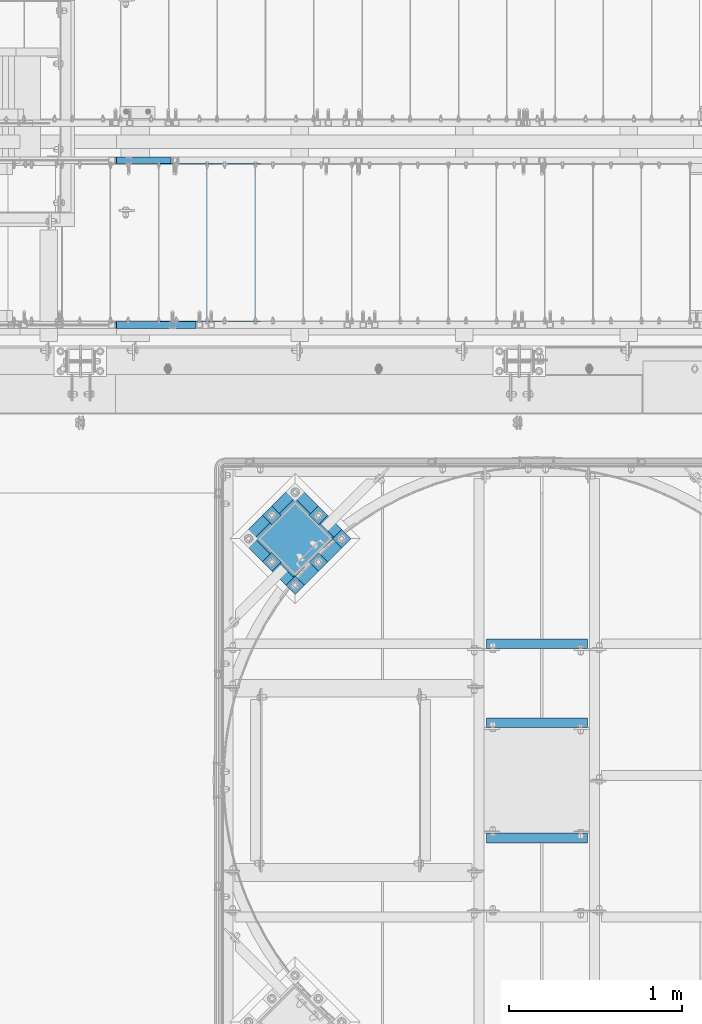
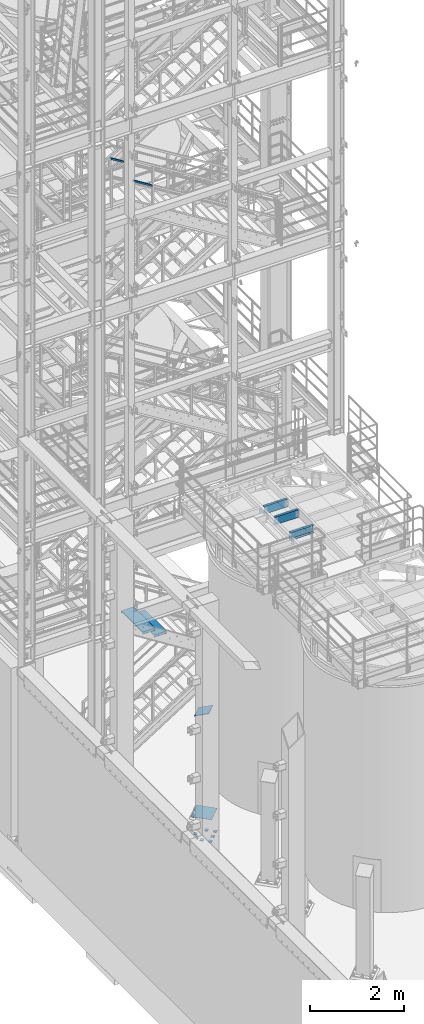
# One storey, part 1142 of 1876: 12 beams, 3 members, 8 elements without a shape of their own.
"""IFC2X3 building model written with IfcOpenShell, lengths in millimetres."""

import ifcopenshell
import ifcopenshell.guid

model = None  # the IFC model being written
_history = None  # IfcOwnerHistory: only IFC2X3 demands one
_inside = {}  # id of a spatial element -> (the spatial element, [elements in it])
_under = {}  # id of a project, library or spatial element -> (it, [spatial elements below it])
_declared = {}  # id of a project -> (the project, [libraries it declares])
_typed = {}  # id of a type object -> (the type object, [elements of that type])
_made_of = {}  # id of a material, layer set ... -> (it, [elements and type objects made of it])


def new_model(schema):
    """Start an empty IFC model of exactly this schema.

    Asked for "IFC4X3", IfcOpenShell would pick the latest addendum, in which some entities
    have other attributes; the version numbers below select the first issue.
    IFC2X3 requires an IfcOwnerHistory on every rooted entity: one is made here for all.
    """
    global model, _history
    if schema == "IFC4X3":
        model = ifcopenshell.file(schema_version=(4, 3, 0, 0))
    else:
        model = ifcopenshell.file(schema=schema)
    _inside.clear()
    _under.clear()
    _declared.clear()
    _typed.clear()
    _made_of.clear()
    _history = None
    if model.schema == "IFC2X3":
        org = make("IfcOrganization", Name="unknown")
        user = make(
            "IfcPersonAndOrganization",
            ThePerson=make("IfcPerson", FamilyName="unknown"),
            TheOrganization=org,
        )
        app = make(
            "IfcApplication",
            ApplicationDeveloper=org,
            Version="unknown",
            ApplicationFullName="unknown",
            ApplicationIdentifier="unknown",
        )
        _history = make(
            "IfcOwnerHistory",
            OwningUser=user,
            OwningApplication=app,
            ChangeAction="ADDED",
            CreationDate=0,
        )
    return model


def make(cls, **values):
    """One entity of the class cls with the attributes given. An attribute that is None is left unset."""
    return model.create_entity(
        cls, **{name: value for name, value in values.items() if value is not None}
    )


def rooted(cls, **values):
    """An entity with a GlobalId (a new one), such as an element, a storey or a relation."""
    return make(cls, GlobalId=ifcopenshell.guid.new(), OwnerHistory=_history, **values)


def si_unit(unit_type, name, prefix=None):
    """IfcSIUnit, for example si_unit("LENGTHUNIT", "METRE", prefix="MILLI")."""
    return make("IfcSIUnit", UnitType=unit_type, Prefix=prefix, Name=name)


def assignment(units):
    """IfcUnitAssignment: the units of a project."""
    return None if units is None else make("IfcUnitAssignment", Units=units)


def point(xyz):
    """IfcCartesianPoint."""
    return None if xyz is None else make("IfcCartesianPoint", Coordinates=xyz)


def direction(xyz):
    """IfcDirection."""
    return None if xyz is None else make("IfcDirection", DirectionRatios=xyz)


def frame(location, z_axis=None, x_axis=None):
    """IfcAxis2Placement3D, a coordinate frame: its origin and axes. An axis left out is left unset."""
    return make(
        "IfcAxis2Placement3D",
        Location=point(location),
        Axis=direction(z_axis),
        RefDirection=direction(x_axis),
    )


def origin_with_axes():
    """The frame at (0, 0, 0) with the z axis (0, 0, 1) and the x axis (1, 0, 0) written out."""
    return frame((0.0, 0.0, 0.0), z_axis=(0.0, 0.0, 1.0), x_axis=(1.0, 0.0, 0.0))


def place(relative_to, where):
    """IfcLocalPlacement: puts the frame where relative to a parent placement (None: the world)."""
    return make(
        "IfcLocalPlacement", PlacementRelTo=relative_to, RelativePlacement=where
    )


def context(
    kind, dimensions, precision=None, world=None, true_north=None, identifier=None
):
    """IfcGeometricRepresentationContext, for example the 3D "Model" context."""
    return make(
        "IfcGeometricRepresentationContext",
        ContextIdentifier=identifier,
        ContextType=kind,
        CoordinateSpaceDimension=dimensions,
        Precision=precision,
        WorldCoordinateSystem=world,
        TrueNorth=true_north,
    )


def subcontext(parent, identifier, kind, view, scale=None):
    """IfcGeometricRepresentationSubContext, for example "Body" below "Model"."""
    return make(
        "IfcGeometricRepresentationSubContext",
        ContextIdentifier=identifier,
        ContextType=kind,
        ParentContext=parent,
        TargetScale=scale,
        TargetView=view,
    )


def project(units=None, contexts=None):
    """IfcProject with its units and contexts."""
    return rooted(
        "IfcProject",
        Name="project",
        RepresentationContexts=contexts,
        UnitsInContext=assignment(units),
    )


def spatial(cls, under=None, at=None, **own):
    """A site, building, storey or space (cls), placed at a placement, below another one or the project."""
    s = rooted(cls, ObjectPlacement=at, **own)
    if under is not None:
        _under.setdefault(under.id(), (under, []))[1].append(s)
    return s


def faces_of(points, faces, orient=None, outer=None):
    """IfcFace entities. A face is a list of loops; a loop is a list of indices into points, from 0.

    orient and outer hold one flag for each loop. By default every Orientation is true, the
    first loop of a face is its IfcFaceOuterBound and the others are IfcFaceBound.
    """
    made = []
    for i, loops in enumerate(faces):
        bounds = []
        for j, loop in enumerate(loops):
            is_outer = j == 0 if outer is None else outer[i][j]
            bounds.append(
                make(
                    "IfcFaceOuterBound" if is_outer else "IfcFaceBound",
                    Bound=make("IfcPolyLoop", Polygon=[points[k] for k in loop]),
                    Orientation=True if orient is None else orient[i][j],
                )
            )
        made.append(make("IfcFace", Bounds=bounds))
    return made


def faceted_brep(points, faces, orient=None, outer=None, voids=None):
    """IfcFacetedBrep: a solid bounded by flat faces; with voids (closed shells), ...WithVoids."""
    shared = [point(p) for p in points]
    hull = make("IfcClosedShell", CfsFaces=faces_of(shared, faces, orient, outer))
    if voids is None:
        return make("IfcFacetedBrep", Outer=hull)
    return make(
        "IfcFacetedBrepWithVoids",
        Outer=hull,
        Voids=[
            make(cls, CfsFaces=faces_of(shared, fs, o, b)) for cls, fs, o, b in voids
        ],
    )


def shape(context_of_items, identifier, shape_type, items):
    """IfcShapeRepresentation: the items that make up one representation, for example the "Body"."""
    return make(
        "IfcShapeRepresentation",
        ContextOfItems=context_of_items,
        RepresentationIdentifier=identifier,
        RepresentationType=shape_type,
        Items=items,
    )


def material(Name=None, Category=None):
    """IfcMaterial."""
    return make("IfcMaterial", Name=Name, Category=Category)


def made_of(thing, what):
    """Note that an element or type object is made of a material, layer set ...; save() writes the relation."""
    if what is not None:
        _made_of.setdefault(what.id(), (what, []))[1].append(thing)
    return thing


def type_object(cls, material=None, **own):
    """A type object (cls), such as IfcWallType, which elements share."""
    return made_of(rooted(cls, **own), material)


def element(
    cls,
    number,
    at=None,
    inside=None,
    cuts=None,
    type_object=None,
    material=None,
    context=None,
    identifier="Body",
    shape_type=None,
    held_by="IfcProductDefinitionShape",
    body=None,
    shapes=None,
    **own,
):
    """One element of the class cls, such as IfcWall. Its Tag is "e" and its number.

    at: its placement. inside: the storey or other place that contains it. cuts: it is an
    opening in that element (IfcRelVoidsElement). A single representation is given by context,
    identifier, shape_type and body (its items); several are given by shapes. held_by: the class
    of the entity that holds the representations. save() writes the other relations.
    """
    e = rooted(cls, Tag="e%d" % number, ObjectPlacement=at, **own)
    if body is not None:
        shapes = [shape(context, identifier, shape_type, body)]
    if shapes is not None:
        e.Representation = make(held_by, Representations=shapes)
    if inside is not None:
        _inside.setdefault(inside.id(), (inside, []))[1].append(e)
    if cuts is not None:
        rooted(
            "IfcRelVoidsElement", RelatingBuildingElement=cuts, RelatedOpeningElement=e
        )
    if type_object is not None:
        _typed.setdefault(type_object.id(), (type_object, []))[1].append(e)
    return made_of(e, material)


def aggregate(whole, parts):
    """IfcRelAggregates: a whole, such as a stair, and the parts it consists of."""
    return rooted("IfcRelAggregates", RelatingObject=whole, RelatedObjects=parts)


def save(model, path):
    """Write the relations noted so far, then the file.

    IfcRelAggregates (storeys below a building ...), IfcRelContainedInSpatialStructure (elements
    in a storey), IfcRelDefinesByType, IfcRelAssociatesMaterial and IfcRelDeclares: one each for
    every whole, place, type object, material and project.
    """
    for whole, parts in _under.values():
        aggregate(whole, parts)
    for where, things in _inside.values():
        rooted(
            "IfcRelContainedInSpatialStructure",
            RelatedElements=things,
            RelatingStructure=where,
        )
    for kind, things in _typed.values():
        rooted("IfcRelDefinesByType", RelatedObjects=things, RelatingType=kind)
    for what, things in _made_of.values():
        rooted("IfcRelAssociatesMaterial", RelatedObjects=things, RelatingMaterial=what)
    for by, libraries in _declared.values():
        rooted("IfcRelDeclares", RelatingContext=by, RelatedDefinitions=libraries)
    model.write(path)


model = new_model("IFC2X3")

# Units and contexts
model_context = context("Model", 3, precision=1e-05, world=origin_with_axes())
body_context = subcontext(model_context, "Body", "Model", "MODEL_VIEW")
ifc_project = project(units=[si_unit("LENGTHUNIT", "METRE", prefix="MILLI"), si_unit("AREAUNIT", "SQUARE_METRE"), si_unit("VOLUMEUNIT", "CUBIC_METRE"), si_unit("MASSUNIT", "GRAM", prefix="KILO"), si_unit("TIMEUNIT", "SECOND"), si_unit("PLANEANGLEUNIT", "RADIAN"), si_unit("SOLIDANGLEUNIT", "STERADIAN"), si_unit("THERMODYNAMICTEMPERATUREUNIT", "DEGREE_CELSIUS"), si_unit("LUMINOUSINTENSITYUNIT", "LUMEN")], contexts=[model_context])

# Site, building, storey
site_placement = place(None, origin_with_axes())
site = spatial("IfcSite", under=ifc_project, at=site_placement, CompositionType="ELEMENT")
building_placement = place(site_placement, origin_with_axes())
building = spatial("IfcBuilding", under=site, at=building_placement, Name="Undefined", CompositionType="ELEMENT")
storey_placement = place(building_placement, origin_with_axes())
storey = spatial("IfcBuildingStorey", under=building, at=storey_placement, Name="Undefined", CompositionType="ELEMENT", Elevation=0.0)

# Assembly, beam
assembly_1_placement = place(storey_placement, origin_with_axes())
assembly_1 = element("IfcElementAssembly", 1, at=assembly_1_placement, inside=storey, Name="BEAM", AssemblyPlace="NOTDEFINED", PredefinedType="RIGID_FRAME")
ifc_material_1 = material(Name="STEEL/A36")
beam_type_1 = type_object("IfcBeamType", Name="C8X11.5", PredefinedType="NOTDEFINED")
beam_1_placement = place(assembly_1_placement, frame((4876.80190734863, -9204.28937988218, 7896.225), z_axis=(0.0, 0.0, -1.0), x_axis=(1.0, 0.0, 0.0)))
beam_1 = element("IfcBeam", 2, at=beam_1_placement, type_object=beam_type_1, material=ifc_material_1, Name="BEAM", ObjectType="C8X11.5", context=body_context, shape_type="Brep", body=[
    faceted_brep([(12.7014315012184, 28.5750000000007, -101.6), (12.7014315012184, 28.5750000000007, 101.6), (596.901431501219, 28.5750000000007, 101.6), (596.901431501219, 28.5750000000007, -101.6), (12.7014315012184, -28.5750000000007, 101.6), (596.901431501219, -28.5750000000007, 101.6), (12.7014315012184, -28.5750000000007, 96.8355949999996), (596.901431501219, -28.5750000000007, 96.8355949999996), (12.7014315012184, 22.2250000000004, 88.3723149999996), (596.901431501219, 22.2250000000004, 88.3723149999996), (12.7014315012184, 22.2250000000004, -88.3723149999996), (596.901431501219, 22.2250000000004, -88.3723149999996), (12.7014315012184, -28.5750000000007, -96.8355949999996), (596.901431501219, -28.5750000000007, -96.8355949999996), (12.7014315012184, -28.5750000000007, -101.6), (596.901431501219, -28.5750000000007, -101.6)], [[[0, 1, 2, 3]], [[1, 4, 5, 2]], [[4, 6, 7, 5]], [[6, 8, 9, 7]], [[8, 10, 11, 9]], [[10, 12, 13, 11]], [[12, 14, 15, 13]], [[14, 0, 3, 15]], [[5, 7, 9, 11, 13, 15, 3, 2]], [[14, 12, 10, 8, 6, 4, 1, 0]]]),
])
aggregate(assembly_1, [beam_1])

assembly_2_placement = place(storey_placement, origin_with_axes())
assembly_2 = element("IfcElementAssembly", 3, at=assembly_2_placement, inside=storey, Name="BEAM", AssemblyPlace="NOTDEFINED", PredefinedType="RIGID_FRAME")
beam_2_placement = place(assembly_2_placement, frame((4876.80333884985, -9871.03937988219, 7896.225), z_axis=(0.0, 0.0, 1.0), x_axis=(1.0, 0.0, 0.0)))
beam_2 = element("IfcBeam", 4, at=beam_2_placement, type_object=beam_type_1, material=ifc_material_1, Name="BEAM", ObjectType="C8X11.5", context=body_context, shape_type="Brep", body=[
    faceted_brep([(12.7000000000007, 28.5749999999998, -101.6), (12.7000000000007, 28.5749999999998, 101.6), (596.900000000001, 28.5750000000007, 101.6), (596.900000000001, 28.5750000000007, -101.6), (12.7000000000007, -28.5749999999998, 101.6), (596.900000000001, -28.5750000000007, 101.6), (12.7000000000007, -28.5749999999998, 96.8355949999996), (596.900000000001, -28.5750000000007, 96.8355949999996), (12.7000000000007, 22.2250000000004, 88.3723149999996), (596.900000000001, 22.2250000000004, 88.3723149999996), (12.7000000000007, 22.2250000000004, -88.3723149999996), (596.900000000001, 22.2250000000004, -88.3723149999996), (12.7000000000007, -28.5749999999998, -96.8355949999996), (596.900000000001, -28.5750000000007, -96.8355949999996), (12.7000000000007, -28.5749999999998, -101.6), (596.900000000001, -28.5750000000007, -101.6)], [[[0, 1, 2, 3]], [[1, 4, 5, 2]], [[4, 6, 7, 5]], [[6, 8, 9, 7]], [[8, 10, 11, 9]], [[10, 12, 13, 11]], [[12, 14, 15, 13]], [[14, 0, 3, 15]], [[5, 7, 9, 11, 13, 15, 3, 2]], [[14, 12, 10, 8, 6, 4, 1, 0]]]),
])
aggregate(assembly_2, [beam_2])

assembly_3_placement = place(storey_placement, origin_with_axes())
assembly_3 = element("IfcElementAssembly", 5, at=assembly_3_placement, inside=storey, Name="BEAM", AssemblyPlace="NOTDEFINED", PredefinedType="RIGID_FRAME")
beam_3_placement = place(assembly_3_placement, frame((4876.80333884985, -8747.08935546873, 7896.225), z_axis=(0.0, 0.0, -1.0), x_axis=(1.0, 0.0, 0.0)))
beam_3 = element("IfcBeam", 6, at=beam_3_placement, type_object=beam_type_1, material=ifc_material_1, Name="BEAM", ObjectType="C8X11.5", context=body_context, shape_type="Brep", body=[
    faceted_brep([(12.7000000000007, 28.5749999999998, -101.6), (12.7000000000007, 28.5749999999998, 101.6), (596.900000000001, 28.5750000000007, 101.6), (596.900000000001, 28.5750000000007, -101.6), (12.7000000000007, -28.5749999999998, 101.6), (596.900000000001, -28.5750000000007, 101.6), (12.7000000000007, -28.5749999999998, 96.8355949999996), (596.900000000001, -28.5750000000007, 96.8355949999996), (12.7000000000007, 22.2250000000004, 88.3723149999996), (596.900000000001, 22.2250000000004, 88.3723149999996), (12.7000000000007, 22.2250000000004, -88.3723149999996), (596.900000000001, 22.2250000000004, -88.3723149999996), (12.7000000000007, -28.5749999999998, -96.8355949999996), (596.900000000001, -28.5750000000007, -96.8355949999996), (12.7000000000007, -28.5749999999998, -101.6), (596.900000000001, -28.5750000000007, -101.6)], [[[0, 1, 2, 3]], [[1, 4, 5, 2]], [[4, 6, 7, 5]], [[6, 8, 9, 7]], [[8, 10, 11, 9]], [[10, 12, 13, 11]], [[12, 14, 15, 13]], [[14, 0, 3, 15]], [[5, 7, 9, 11, 13, 15, 3, 2]], [[14, 12, 10, 8, 6, 4, 1, 0]]]),
])
aggregate(assembly_3, [beam_3])

# Assembly, member
assembly_4_placement = place(storey_placement, origin_with_axes())
assembly_4 = element("IfcElementAssembly", 7, at=assembly_4_placement, inside=storey, Name="COLUMN", AssemblyPlace="NOTDEFINED", PredefinedType="RIGID_FRAME")
member_type_1 = type_object("IfcMemberType", PredefinedType="NOTDEFINED")
member_1_placement = place(assembly_4_placement, frame((3889.24355300666, -8245.19773813303, 2749.16704824061), z_axis=(0.707106781186548, 0.707106781186547, 0.0), x_axis=(-0.664463024761457, 0.664463024761458, -0.342020141877214)))
member_1 = element("IfcMember", 8, at=member_1_placement, type_object=member_type_1, material=ifc_material_1, Name="PLATE", context=body_context, shape_type="Brep", body=[
    faceted_brep([(0.0, 6.35000000000042, -165.100000000026), (0.0, 6.35000000000042, 165.100000000029), (337.061384869998, 6.34999999999997, 165.099999999921), (337.061384869996, 6.34999999999997, -165.100000000135), (1.81898940354586e-12, -6.34999999999849, 165.100000000029), (337.061384869998, -6.3499999999994, 165.099999999921), (0.0, -6.34999999999894, -165.100000000026), (337.061384869998, -6.3499999999994, -165.100000000136)], [[[0, 1, 2, 3]], [[1, 4, 5, 2]], [[4, 6, 7, 5]], [[6, 0, 3, 7]], [[5, 7, 3, 2]], [[6, 4, 1, 0]]]),
])
aggregate(assembly_4, [member_1])

# Assembly, beams
assembly_5_placement = place(storey_placement, origin_with_axes())
assembly_5 = element("IfcElementAssembly", 9, at=assembly_5_placement, inside=storey, Name="TEMPLATE", AssemblyPlace="NOTDEFINED", PredefinedType="RIGID_FRAME")
beam_type_2 = type_object("IfcBeamType", PredefinedType="NOTDEFINED")
beam_4_placement = place(assembly_5_placement, frame((4079.3646457972, -8112.02961055577, -542.925), z_axis=(-0.707106781186548, 0.707106781186547, 0.0), x_axis=(-0.707106781186547, -0.707106781186548, 0.0)))
beam_4 = element("IfcBeam", 10, at=beam_4_placement, type_object=beam_type_2, material=ifc_material_1, Name="PLATE", context=body_context, shape_type="Brep", body=[
    faceted_brep([(0.0, 9.52499999999998, -38.1000000000058), (-9.09494701772928e-13, 9.52499999999998, 38.1000000000076), (76.2000000000762, 9.52499999999998, 38.1000000000058), (76.2000000000762, 9.52499999999998, -38.1000000000058), (-9.09494701772928e-13, -9.52499999999998, 38.1000000000076), (76.2000000000762, -9.52499999999998, 38.1000000000058), (0.0, -9.52499999999998, -38.1000000000058), (76.2000000000762, -9.52499999999998, -38.1000000000058)], [[[0, 1, 2, 3]], [[1, 4, 5, 2]], [[4, 6, 7, 5]], [[6, 0, 3, 7]], [[5, 7, 3, 2]], [[6, 4, 1, 0]]]),
])
beam_5_placement = place(assembly_5_placement, frame((3944.66080398105, -7977.32576873962, -542.925), z_axis=(-0.707106781186548, 0.707106781186547, 0.0), x_axis=(-0.707106781186547, -0.707106781186548, 0.0)))
beam_5 = element("IfcBeam", 11, at=beam_5_placement, type_object=beam_type_2, material=ifc_material_1, Name="PLATE", context=body_context, shape_type="Brep", body=[
    faceted_brep([(0.0, 9.52499999999998, -38.1000000000058), (-9.09494701772928e-13, 9.52499999999998, 38.1000000000076), (76.2000000000762, 9.52499999999998, 38.1000000000058), (76.2000000000762, 9.52499999999998, -38.1000000000058), (-9.09494701772928e-13, -9.52499999999998, 38.1000000000076), (76.2000000000762, -9.52499999999998, 38.1000000000058), (0.0, -9.52499999999998, -38.1000000000058), (76.2000000000762, -9.52499999999998, -38.1000000000058)], [[[0, 1, 2, 3]], [[1, 4, 5, 2]], [[4, 6, 7, 5]], [[6, 0, 3, 7]], [[5, 7, 3, 2]], [[6, 4, 1, 0]]]),
])
beam_6_placement = place(assembly_5_placement, frame((3944.66080398105, -8246.73345237192, -542.925), z_axis=(-0.707106781186548, 0.707106781186547, 0.0), x_axis=(-0.707106781186547, -0.707106781186548, 0.0)))
beam_6 = element("IfcBeam", 12, at=beam_6_placement, type_object=beam_type_2, material=ifc_material_1, Name="PLATE", context=body_context, shape_type="Brep", body=[
    faceted_brep([(0.0, 9.52499999999998, -38.1000000000058), (-9.09494701772928e-13, 9.52499999999998, 38.1000000000076), (76.2000000000762, 9.52499999999998, 38.1000000000058), (76.2000000000762, 9.52499999999998, -38.1000000000058), (-9.09494701772928e-13, -9.52499999999998, 38.1000000000076), (76.2000000000762, -9.52499999999998, 38.1000000000058), (0.0, -9.52499999999998, -38.1000000000058), (76.2000000000762, -9.52499999999998, -38.1000000000058)], [[[0, 1, 2, 3]], [[1, 4, 5, 2]], [[4, 6, 7, 5]], [[6, 0, 3, 7]], [[5, 7, 3, 2]], [[6, 4, 1, 0]]]),
])
beam_7_placement = place(assembly_5_placement, frame((3675.25312034875, -7977.32576873961, -542.925), z_axis=(-0.707106781186548, 0.707106781186547, 0.0), x_axis=(-0.707106781186547, -0.707106781186548, 0.0)))
beam_7 = element("IfcBeam", 13, at=beam_7_placement, type_object=beam_type_2, material=ifc_material_1, Name="PLATE", context=body_context, shape_type="Brep", body=[
    faceted_brep([(0.0, 9.52499999999998, -38.1000000000058), (-9.09494701772928e-13, 9.52499999999998, 38.1000000000076), (76.2000000000762, 9.52499999999998, 38.1000000000058), (76.2000000000762, 9.52499999999998, -38.1000000000058), (-9.09494701772928e-13, -9.52499999999998, 38.1000000000076), (76.2000000000762, -9.52499999999998, 38.1000000000058), (0.0, -9.52499999999998, -38.1000000000058), (76.2000000000762, -9.52499999999998, -38.1000000000058)], [[[0, 1, 2, 3]], [[1, 4, 5, 2]], [[4, 6, 7, 5]], [[6, 0, 3, 7]], [[5, 7, 3, 2]], [[6, 4, 1, 0]]]),
])
beam_8_placement = place(assembly_5_placement, frame((3809.9569621649, -8381.43729418807, -542.925), z_axis=(-0.707106781186548, 0.707106781186547, 0.0), x_axis=(-0.707106781186547, -0.707106781186548, 0.0)))
beam_8 = element("IfcBeam", 14, at=beam_8_placement, type_object=beam_type_2, material=ifc_material_1, Name="PLATE", context=body_context, shape_type="Brep", body=[
    faceted_brep([(0.0, 9.52499999999998, -38.1000000000058), (-9.09494701772928e-13, 9.52499999999998, 38.1000000000076), (76.2000000000762, 9.52499999999998, 38.1000000000058), (76.2000000000762, 9.52499999999998, -38.1000000000058), (-9.09494701772928e-13, -9.52499999999998, 38.1000000000076), (76.2000000000762, -9.52499999999998, 38.1000000000058), (0.0, -9.52499999999998, -38.1000000000058), (76.2000000000762, -9.52499999999998, -38.1000000000058)], [[[0, 1, 2, 3]], [[1, 4, 5, 2]], [[4, 6, 7, 5]], [[6, 0, 3, 7]], [[5, 7, 3, 2]], [[6, 4, 1, 0]]]),
])
beam_9_placement = place(assembly_5_placement, frame((3675.25312034875, -8246.73345237191, -542.925), z_axis=(-0.707106781186548, 0.707106781186547, 0.0), x_axis=(-0.707106781186547, -0.707106781186548, 0.0)))
beam_9 = element("IfcBeam", 15, at=beam_9_placement, type_object=beam_type_2, material=ifc_material_1, Name="PLATE", context=body_context, shape_type="Brep", body=[
    faceted_brep([(0.0, 9.52499999999998, -38.1000000000058), (-9.09494701772928e-13, 9.52499999999998, 38.1000000000076), (76.2000000000762, 9.52499999999998, 38.1000000000058), (76.2000000000762, 9.52499999999998, -38.1000000000058), (-9.09494701772928e-13, -9.52499999999998, 38.1000000000076), (76.2000000000762, -9.52499999999998, 38.1000000000058), (0.0, -9.52499999999998, -38.1000000000058), (76.2000000000762, -9.52499999999998, -38.1000000000058)], [[[0, 1, 2, 3]], [[1, 4, 5, 2]], [[4, 6, 7, 5]], [[6, 0, 3, 7]], [[5, 7, 3, 2]], [[6, 4, 1, 0]]]),
])
beam_type_3 = type_object("IfcBeamType", PredefinedType="NOTDEFINED")
beam_10_placement = place(assembly_5_placement, frame((3944.66080398091, -7977.32576873953, 40.4815), z_axis=(0.707106781186547, -0.707106781186548, 0.0), x_axis=(-0.707106781186547, -0.707106781186548, 0.0)))
beam_10 = element("IfcBeam", 16, at=beam_10_placement, type_object=beam_type_3, material=ifc_material_1, Name="TEMPLATE", context=body_context, shape_type="Brep", body=[
    faceted_brep([(9.09494701772928e-13, 2.3815, -228.600000000035), (-9.09494701772928e-13, 2.3815, 228.60000000004), (457.200000000363, 2.3815, 228.60000000004), (457.200000000362, 2.3815, -228.600000000037), (-9.09494701772928e-13, -2.3815, 228.60000000004), (457.200000000363, -2.3815, 228.60000000004), (9.09494701772928e-13, -2.3815, -228.600000000035), (457.200000000362, -2.3815, -228.600000000037)], [[[0, 1, 2, 3]], [[1, 4, 5, 2]], [[4, 6, 7, 5]], [[6, 0, 3, 7]], [[5, 7, 3, 2]], [[6, 4, 1, 0]]]),
])
aggregate(assembly_5, [beam_4, beam_5, beam_6, beam_7, beam_8, beam_9, beam_10])

# Assembly, member
assembly_6_placement = place(storey_placement, origin_with_axes())
assembly_6 = element("IfcElementAssembly", 17, at=assembly_6_placement, inside=storey, Name="RAIL", AssemblyPlace="NOTDEFINED", PredefinedType="RIGID_FRAME")
ifc_material_2 = material()
member_type_2 = type_object("IfcMemberType", Name="HSS1-1/2X1-1/2X1/8", PredefinedType="NOTDEFINED")
member_2_placement = place(assembly_6_placement, frame((3229.61016453362, -6902.45000114819, 15801.439963085), z_axis=(0.526640055094465, 0.0, 0.850088379152485), x_axis=(-0.850088379152485, 0.0, 0.526640055094466)))
member_2 = element("IfcMember", 18, at=member_2_placement, type_object=member_type_2, material=ifc_material_2, Name="RAIL", ObjectType="HSS1-1/2X1-1/2X1/8", context=body_context, shape_type="Brep", body=[
    faceted_brep([(12.5746792883347, 15.8749992829999, -15.874999283018), (12.5746792883347, -15.8749992829999, -15.874999283018), (567.668633956618, -15.8749992829999, -15.8749992834546), (567.668633956618, 15.8749992829999, -15.8749992834546), (32.2441882524263, -15.8749992829999, 15.8749992829798), (576.706483818847, -15.8749992829999, 15.8749992825542), (32.2441882524263, 15.8749992829999, 15.8749992829798), (576.706483818847, 15.8749992829999, 15.8749992825542), (10.6077283328268, 19.0499992349996, -19.0499992350178), (34.2111392079378, 19.0499992349996, 19.0499992349814), (577.610268832225, 19.0499992349996, 19.049999234554), (566.764848943239, 19.0499992349996, -19.0499992354562), (34.2111392079378, -19.0499992349996, 19.0499992349814), (577.610268832225, -19.0499992349996, 19.049999234554), (10.6077283328268, -19.0499992349996, -19.0499992350178), (566.764848943239, -19.0499992349996, -19.0499992354562)], [[[0, 1, 2, 3]], [[1, 4, 5, 2]], [[4, 6, 7, 5]], [[6, 0, 3, 7]], [[8, 9, 10, 11]], [[9, 12, 13, 10]], [[12, 14, 15, 13]], [[14, 8, 11, 15]], [[13, 15, 11, 10], [5, 7, 3, 2]], [[14, 12, 9, 8], [6, 4, 1, 0]]]),
])
aggregate(assembly_6, [member_2])

assembly_7_placement = place(storey_placement, origin_with_axes())
assembly_7 = element("IfcElementAssembly", 19, at=assembly_7_placement, inside=storey, Name="RAIL", AssemblyPlace="NOTDEFINED", PredefinedType="RIGID_FRAME")
member_3_placement = place(assembly_7_placement, frame((3082.92516450776, -5949.95000114554, 15892.313098621), z_axis=(0.526640055094465, 0.0, 0.850088379152485), x_axis=(-0.850088379152485, 0.0, 0.526640055094466)))
member_3 = element("IfcMember", 20, at=member_3_placement, type_object=member_type_2, material=ifc_material_2, Name="RAIL", ObjectType="HSS1-1/2X1-1/2X1/8", context=body_context, shape_type="Brep", body=[
    faceted_brep([(12.5746792883347, 15.8749992829999, -15.874999283018), (12.5746792883347, -15.8749992829999, -15.874999283018), (395.11598730638, -15.8749992829999, -15.8749992833164), (395.11598730638, 15.8749992829999, -15.8749992833164), (32.2441882524263, -15.8749992829999, 15.8749992829798), (404.153837168608, -15.8749992829999, 15.8749992826906), (32.2441882524263, 15.8749992829999, 15.8749992829798), (404.153837168608, 15.8749992829999, 15.8749992826906), (10.6077283328268, 19.0499992349996, -19.0499992350178), (34.2111392079378, 19.0499992349996, 19.0499992349814), (405.057622181987, 19.0499992349996, 19.0499992346922), (394.212202293001, 19.0499992349996, -19.049999235318), (34.2111392079378, -19.0499992349996, 19.0499992349814), (405.057622181987, -19.0499992349996, 19.0499992346922), (10.6077283328268, -19.0499992349996, -19.0499992350178), (394.212202293001, -19.0499992349996, -19.049999235318)], [[[0, 1, 2, 3]], [[1, 4, 5, 2]], [[4, 6, 7, 5]], [[6, 0, 3, 7]], [[8, 9, 10, 11]], [[9, 12, 13, 10]], [[12, 14, 15, 13]], [[14, 8, 11, 15]], [[13, 15, 11, 10], [5, 7, 3, 2]], [[14, 12, 9, 8], [6, 4, 1, 0]]]),
])
aggregate(assembly_7, [member_3])

# Assembly, beams
assembly_8_placement = place(storey_placement, origin_with_axes())
assembly_8 = element("IfcElementAssembly", 21, at=assembly_8_placement, inside=storey, Name="STRINGER", AssemblyPlace="NOTDEFINED", PredefinedType="RIGID_FRAME")
beam_type_4 = type_object("IfcBeamType", PredefinedType="NOTDEFINED")
beam_11_placement = place(assembly_8_placement, frame((3148.01250451836, -5973.76300113357, 4244.5370689685), z_axis=(1.0, 0.0, 0.0), x_axis=(0.0, -1.0, 0.0)))
beam_11 = element("IfcBeam", 22, at=beam_11_placement, type_object=beam_type_4, material=ifc_material_1, Name="TREAD", context=body_context, shape_type="Brep", body=[
    faceted_brep([(-7.45785655453801e-11, 53.9750000000167, -153.9875), (-7.45785655453801e-11, 53.9750000000167, 153.987506103515), (0.0, 9.52499999999964, 153.9875), (-7.45785655453801e-11, 9.52499999999964, -153.9875), (-4.76300000007541, 53.9750000000167, -153.9875), (-4.76300000007541, 53.9750000000167, 153.987506103515), (-4.76300000007541, -9.52499999998327, -153.9875), (-4.76300000007541, -9.52500000019427, 153.987536621094), (909.637000008669, -9.52500000248983, 153.987506103515), (909.637000008669, 53.9749999975102, 153.987506103515), (904.87400000867, 53.9749999975102, 153.987506103515), (904.87400000867, 9.52499999999964, 153.987506103515), (-7.45785655453801e-11, -9.52500000019427, 153.987536621094), (904.87400000867, -9.52500000248983, 153.987506103515), (904.87400000867, 9.52499999999964, -153.9875), (909.637000008669, -9.52500000248983, -153.9875), (909.637000008669, 53.9749999975102, -153.9875), (904.87400000867, 53.9749999975102, -153.9875)], [[[0, 1, 2, 3]], [[1, 0, 4, 5]], [[5, 4, 6, 7]], [[8, 9, 10, 11, 2, 1, 5, 7, 12, 13]], [[14, 3, 2, 11]], [[15, 8, 13, 12, 7, 6]], [[9, 16, 17, 10]], [[16, 9, 8, 15]], [[16, 15, 6, 4, 0, 3, 14, 17]], [[10, 17, 14, 11]]]),
])
beam_12_placement = place(assembly_8_placement, frame((3427.41250420055, -5973.76300113341, 4067.28448276185), z_axis=(1.0, 0.0, 0.0), x_axis=(0.0, -1.0, 0.0)))
beam_12 = element("IfcBeam", 23, at=beam_12_placement, type_object=beam_type_4, material=ifc_material_1, Name="TREAD", context=body_context, shape_type="Brep", body=[
    faceted_brep([(-7.45785655453801e-11, 53.9750000000167, -153.9875), (-7.45785655453801e-11, 53.9750000000167, 153.987506103515), (0.0, 9.52499999999964, 153.9875), (-7.45785655453801e-11, 9.52499999999964, -153.9875), (-4.76300000007541, 53.9750000000167, -153.9875), (-4.76300000007541, 53.9750000000167, 153.987506103515), (-4.76300000007541, -9.52499999998327, -153.9875), (-4.76300000007541, -9.52500000019427, 153.987536621094), (909.637000008669, -9.52500000248983, 153.987506103515), (909.637000008669, 53.9749999975102, 153.987506103515), (904.87400000867, 53.9749999975102, 153.987506103515), (904.87400000867, 9.52499999999964, 153.987506103515), (-7.45785655453801e-11, -9.52500000019427, 153.987536621094), (904.87400000867, -9.52500000248983, 153.987506103515), (904.87400000867, 9.52499999999964, -153.9875), (909.637000008669, -9.52500000248983, -153.9875), (909.637000008669, 53.9749999975102, -153.9875), (904.87400000867, 53.9749999975102, -153.9875)], [[[0, 1, 2, 3]], [[1, 0, 4, 5]], [[5, 4, 6, 7]], [[8, 9, 10, 11, 2, 1, 5, 7, 12, 13]], [[14, 3, 2, 11]], [[15, 8, 13, 12, 7, 6]], [[9, 16, 17, 10]], [[16, 9, 8, 15]], [[16, 15, 6, 4, 0, 3, 14, 17]], [[10, 17, 14, 11]]]),
])
aggregate(assembly_8, [beam_11, beam_12])

save(model, "model.ifc")
